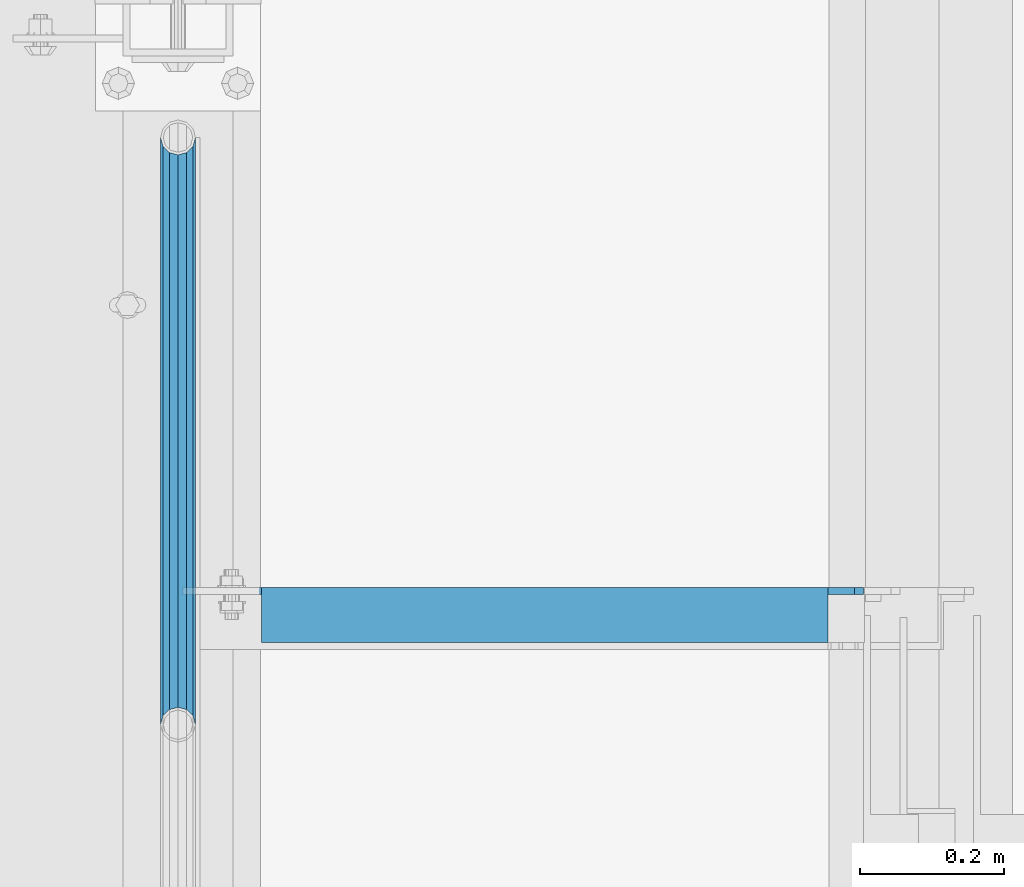
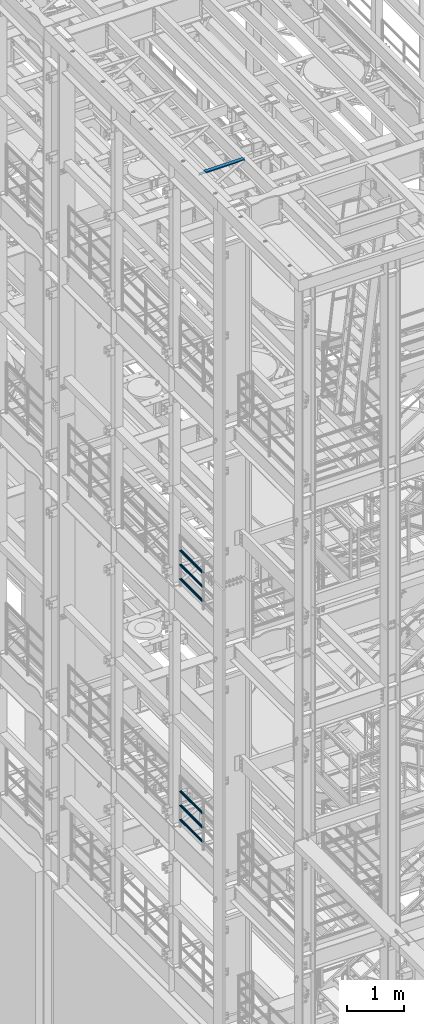
# One storey, part 1179 of 1876: 7 beams, 3 elements without a shape of their own.
"""IFC2X3 building model written with IfcOpenShell, lengths in millimetres."""

from ifc_helpers import new_model, si_unit, frame, origin_with_axes, place, context, subcontext, project, spatial, faceted_brep, material, type_object, element, aggregate, save


model = new_model("IFC2X3")

# Units and contexts
model_context = context("Model", 3, precision=1e-05, world=origin_with_axes())
body_context = subcontext(model_context, "Body", "Model", "MODEL_VIEW")
ifc_project = project(units=[si_unit("LENGTHUNIT", "METRE", prefix="MILLI"), si_unit("AREAUNIT", "SQUARE_METRE"), si_unit("VOLUMEUNIT", "CUBIC_METRE"), si_unit("MASSUNIT", "GRAM", prefix="KILO"), si_unit("TIMEUNIT", "SECOND"), si_unit("PLANEANGLEUNIT", "RADIAN"), si_unit("SOLIDANGLEUNIT", "STERADIAN"), si_unit("THERMODYNAMICTEMPERATUREUNIT", "DEGREE_CELSIUS"), si_unit("LUMINOUSINTENSITYUNIT", "LUMEN")], contexts=[model_context])

# Site, building, storey
site_placement = place(None, origin_with_axes())
site = spatial("IfcSite", under=ifc_project, at=site_placement, CompositionType="ELEMENT")
building_placement = place(site_placement, origin_with_axes())
building = spatial("IfcBuilding", under=site, at=building_placement, Name="Undefined", CompositionType="ELEMENT")
storey_placement = place(building_placement, origin_with_axes())
storey = spatial("IfcBuildingStorey", under=building, at=storey_placement, Name="Undefined", CompositionType="ELEMENT", Elevation=0.0)

# Assembly, beams
assembly_1_placement = place(storey_placement, origin_with_axes())
assembly_1 = element("IfcElementAssembly", 1, at=assembly_1_placement, inside=storey, Name="RAIL", AssemblyPlace="NOTDEFINED", PredefinedType="RIGID_FRAME")
ifc_material_1 = material()
beam_type_1 = type_object("IfcBeamType", Name="PIPE1-1/2SCH40", PredefinedType="NOTDEFINED")
beam_1_placement = place(assembly_1_placement, frame((3.15234098531586e-11, -2729.3062, 13471.525), z_axis=(0.0, 0.0, 1.0), x_axis=(0.0, -1.0, 0.0)))
beam_1 = element("IfcBeam", 2, at=beam_1_placement, type_object=beam_type_1, material=ifc_material_1, Name="RAIL", ObjectType="PIPE1-1/2SCH40", context=body_context, shape_type="Brep", body=[
    faceted_brep([(792.499707006684, -12.0649999999996, 20.8971929933177), (792.499707006684, -12.0650000000314, 15.8661214311469), (792.006278568813, -10.2235000000001, 17.7076214311819), (789.266900000001, -9.09494701772928e-13, 20.4470000000001), (789.266900000001, -9.09494701772928e-13, 24.130000000001), (792.00627856883, 10.2235000000001, 17.7076214311819), (792.499707006684, 12.0649999999678, 15.8661214312124), (792.499707006684, 12.0649999999996, 20.8971929933177), (813.396900000002, 24.1300000000001, 0.0), (801.331900000001, 20.8971929933186, 12.0649999999987), (801.331900000001, 20.8971929933186, -12.0649999999987), (798.142328437896, 17.7076214311801, 10.2235000000001), (800.881707006714, 20.4470000000001, 0.0), (798.142328437896, 17.7076214311801, -10.2235000000001), (792.499707006684, 12.0649999999678, -15.8661214312124), (792.499707006684, 12.0649999999996, -20.8971929933177), (792.00627856883, 10.2235000000001, -17.7076214311819), (789.266900000001, 0.0, -20.4470000000001), (789.266900000001, 0.0, -24.130000000001), (792.499707006684, -12.0650000000314, -15.8661214311469), (792.499707006684, -12.0649999999996, -20.8971929933177), (792.006278568813, -10.2235000000001, -17.7076214311819), (813.396900000002, -24.1300000000319, 0.0), (801.331900000001, -20.8971929933186, -12.0649999999987), (801.331900000001, -20.8971929933186, 12.0649999999987), (798.142328437831, -17.7076214311801, -10.2235000000001), (800.881707006651, -20.4470000000001, 0.0), (798.142328437831, -17.7076214311801, 10.2235000000001), (12.0650000000064, -20.8971929933177, -12.0649999999987), (20.8971929933249, -12.0650000000005, -20.8971929933177), (0.0, 24.1299999999992, 0.0), (12.0650000000064, 20.8971929933177, -12.0649999999987), (12.0650000000064, 20.8971929933177, 12.0649999999987), (20.8971929933249, 12.0650000000005, 20.8971929933177), (24.1300000000064, 0.0, 24.130000000001), (20.8971929933249, 12.0650000000005, -20.8971929933177), (24.1300000000063, 0.0, -24.130000000001), (24.1300000000063, 0.0, -20.4470000000001), (20.8971929933249, -12.0650000000005, -15.8661214311796), (21.3906214311868, -10.2235000000001, -17.7076214311819), (21.3906214311868, 10.2235000000001, -17.7076214311819), (20.8971929933249, 12.0650000000005, -15.8661214311796), (15.2545715621445, 17.7076214311801, -10.2235000000001), (12.5151929933249, 20.4470000000001, 0.0), (15.2545715621445, 17.7076214311801, 10.2235000000001), (20.8971929933249, 12.0650000000005, 15.8661214311796), (21.3906214311868, 10.2235000000001, 17.7076214311819), (24.1300000000064, 0.0, 20.4470000000001), (21.3906214311868, -10.2235000000001, 17.7076214311819), (20.8971929933249, -12.0650000000005, 15.8661214311796), (20.8971929933249, -12.0650000000005, 20.8971929933177), (12.0650000000064, -20.8971929933177, 12.0649999999987), (0.0, -24.1299999999992, 0.0), (15.2545715621445, -17.7076214311801, 10.2235000000001), (12.5151929933249, -20.4470000000001, 0.0), (15.2545715621445, -17.7076214311801, -10.2235000000001)], [[[0, 1, 2, 3, 4]], [[4, 3, 5, 6, 7]], [[8, 9, 10]], [[7, 6, 11, 12, 13, 14, 15, 10, 9]], [[16, 17, 18, 15, 14]], [[19, 20, 18, 17, 21]], [[22, 23, 24]], [[24, 23, 20, 19, 25, 26, 27, 1, 0]], [[28, 29, 20, 23]], [[30, 31, 32]], [[33, 34, 4, 7]], [[32, 33, 7, 9]], [[30, 32, 9, 8]], [[31, 30, 8, 10]], [[35, 31, 10, 15]], [[36, 35, 15, 18]], [[29, 36, 18, 20]], [[37, 36, 29, 38, 39]], [[40, 41, 35, 36, 37]], [[32, 31, 35, 41, 42, 43, 44, 45, 33]], [[33, 45, 46, 47, 34]], [[34, 47, 48, 49, 50]], [[34, 50, 0, 4]], [[50, 51, 24, 0]], [[51, 52, 22, 24]], [[52, 28, 23, 22]], [[51, 28, 52]], [[50, 49, 53, 54, 55, 38, 29, 28, 51]], [[55, 54, 26, 25]], [[21, 39, 38, 55, 25, 19]], [[37, 39, 21, 17]], [[40, 37, 17, 16]], [[42, 41, 40, 16, 14, 13]], [[43, 42, 13, 12]], [[44, 43, 12, 11]], [[5, 46, 45, 44, 11, 6]], [[47, 46, 5, 3]], [[48, 47, 3, 2]], [[53, 49, 48, 2, 1, 27]], [[54, 53, 27, 26]]]),
])
beam_2_placement = place(assembly_1_placement, frame((-1.81898940354586e-12, -3542.7031, 13776.325), z_axis=(0.0, 0.0, -1.0), x_axis=(0.0, 1.0, 0.0)))
beam_2 = element("IfcBeam", 3, at=beam_2_placement, type_object=beam_type_1, material=ifc_material_1, Name="RAIL", ObjectType="PIPE1-1/2SCH40", context=body_context, shape_type="Brep", body=[
    faceted_brep([(0.0, 24.1299999999992, 0.0), (12.0650000000064, 20.8971929933177, -12.0649999999987), (12.0650000000064, 20.8971929933177, 12.0649999999987), (12.0650000000064, -20.8971929933177, 12.0649999999987), (12.0650000000064, -20.8971929933177, -12.0649999999987), (0.0, -24.1299999999992, 0.0), (20.8971929933249, -12.0650000000005, 20.8971929933177), (20.8971929933249, -12.0650000000005, 15.8661214311796), (15.2545715621445, -17.7076214311801, 10.2235000000001), (12.5151929933249, -20.4470000000001, 0.0), (15.2545715621445, -17.7076214311801, -10.2235000000001), (20.8971929933249, -12.0650000000005, -15.8661214311796), (20.8971929933249, -12.0650000000005, -20.8971929933177), (24.1300000000063, 0.0, -20.4470000000001), (24.1300000000063, 0.0, -24.130000000001), (21.3906214311868, -10.2235000000001, -17.7076214311819), (21.3906214311868, 10.2235000000001, -17.7076214311819), (20.8971929933249, 12.0650000000005, -15.8661214311796), (20.8971929933249, 12.0650000000005, -20.8971929933177), (15.2545715621445, 17.7076214311801, -10.2235000000001), (12.5151929933249, 20.4470000000001, 0.0), (15.2545715621445, 17.7076214311801, 10.2235000000001), (20.8971929933249, 12.0650000000005, 15.8661214311796), (20.8971929933249, 12.0650000000005, 20.8971929933177), (21.3906214311868, 10.2235000000001, 17.7076214311819), (24.1300000000064, 0.0, 20.4470000000001), (24.1300000000064, 0.0, 24.130000000001), (21.3906214311868, -10.2235000000001, 17.7076214311819), (813.396900000002, 24.1300000000001, 0.0), (801.331900000001, 20.8971929933186, -12.0649999999987), (792.499707006684, 12.0649999999996, -20.8971929933177), (813.396900000002, -24.1300000000319, 0.0), (801.331900000001, -20.8971929933186, -12.0649999999987), (801.331900000001, -20.8971929933186, 12.0649999999987), (792.499707006684, -12.0649999999996, 20.8971929933177), (792.499707006684, -12.0649999999996, -20.8971929933177), (789.266900000001, 0.0, -24.130000000001), (792.00627856883, 10.2235000000001, -17.7076214311819), (789.266900000001, 0.0, -20.4470000000001), (792.499707006684, 12.0649999999678, -15.8661214312124), (792.499707006684, -12.0650000000314, -15.8661214311469), (792.006278568813, -10.2235000000001, -17.7076214311819), (798.142328437831, -17.7076214311801, -10.2235000000001), (800.881707006651, -20.4470000000001, 0.0), (798.142328437831, -17.7076214311801, 10.2235000000001), (792.499707006684, -12.0650000000314, 15.8661214311469), (792.006278568813, -10.2235000000001, 17.7076214311819), (789.266900000001, -9.09494701772928e-13, 20.4470000000001), (789.266900000001, -9.09494701772928e-13, 24.130000000001), (792.499707006684, 12.0649999999996, 20.8971929933177), (801.331900000001, 20.8971929933186, 12.0649999999987), (792.499707006684, 12.0649999999678, 15.8661214312124), (798.142328437896, 17.7076214311801, 10.2235000000001), (800.881707006714, 20.4470000000001, 0.0), (798.142328437896, 17.7076214311801, -10.2235000000001), (792.00627856883, 10.2235000000001, 17.7076214311819)], [[[0, 1, 2]], [[3, 4, 5]], [[6, 7, 8, 9, 10, 11, 12, 4, 3]], [[13, 14, 12, 11, 15]], [[16, 17, 18, 14, 13]], [[2, 1, 18, 17, 19, 20, 21, 22, 23]], [[23, 22, 24, 25, 26]], [[26, 25, 27, 7, 6]], [[1, 0, 28, 29]], [[18, 1, 29, 30]], [[31, 32, 33]], [[6, 3, 33, 34]], [[3, 5, 31, 33]], [[5, 4, 32, 31]], [[4, 12, 35, 32]], [[12, 14, 36, 35]], [[14, 18, 30, 36]], [[37, 38, 36, 30, 39]], [[40, 35, 36, 38, 41]], [[33, 32, 35, 40, 42, 43, 44, 45, 34]], [[34, 45, 46, 47, 48]], [[26, 6, 34, 48]], [[2, 23, 49, 50]], [[23, 26, 48, 49]], [[0, 2, 50, 28]], [[28, 50, 29]], [[49, 51, 52, 53, 54, 39, 30, 29, 50]], [[48, 47, 55, 51, 49]], [[25, 24, 55, 47]], [[55, 24, 22, 21, 52, 51]], [[21, 20, 53, 52]], [[20, 19, 54, 53]], [[19, 17, 16, 37, 39, 54]], [[16, 13, 38, 37]], [[13, 15, 41, 38]], [[41, 15, 11, 10, 42, 40]], [[10, 9, 43, 42]], [[9, 8, 44, 43]], [[8, 7, 27, 46, 45, 44]], [[27, 25, 47, 46]]]),
])
beam_3_placement = place(assembly_1_placement, frame((-1.81898940354586e-12, -3542.7031, 14081.125), z_axis=(0.0, 0.0, -1.0), x_axis=(0.0, 1.0, 0.0)))
beam_3 = element("IfcBeam", 4, at=beam_3_placement, type_object=beam_type_1, material=ifc_material_1, Name="RAIL", ObjectType="PIPE1-1/2SCH40", context=body_context, shape_type="Brep", body=[
    faceted_brep([(0.0, 24.1299999999992, 0.0), (12.0650000000064, 20.8971929933177, -12.0649999999987), (12.0650000000064, 20.8971929933177, 12.0649999999987), (12.0650000000064, -20.8971929933177, 12.0649999999987), (12.0650000000064, -20.8971929933177, -12.0649999999987), (0.0, -24.1299999999992, 0.0), (20.8971929933249, -12.0650000000005, 20.8971929933177), (20.8971929933249, -12.0650000000005, 15.8661214311796), (15.2545715621445, -17.7076214311801, 10.2235000000001), (12.5151929933249, -20.4470000000001, 0.0), (15.2545715621445, -17.7076214311801, -10.2235000000001), (20.8971929933249, -12.0650000000005, -15.8661214311796), (20.8971929933249, -12.0650000000005, -20.8971929933177), (24.1300000000063, 0.0, -20.4470000000001), (24.1300000000063, 0.0, -24.130000000001), (21.3906214311868, -10.2235000000001, -17.7076214311819), (21.3906214311868, 10.2235000000001, -17.7076214311819), (20.8971929933249, 12.0650000000005, -15.8661214311796), (20.8971929933249, 12.0650000000005, -20.8971929933177), (15.2545715621445, 17.7076214311801, -10.2235000000001), (12.5151929933249, 20.4470000000001, 0.0), (15.2545715621445, 17.7076214311801, 10.2235000000001), (20.8971929933249, 12.0650000000005, 15.8661214311796), (20.8971929933249, 12.0650000000005, 20.8971929933177), (21.3906214311868, 10.2235000000001, 17.7076214311819), (24.1300000000064, 0.0, 20.4470000000001), (24.1300000000064, 0.0, 24.130000000001), (21.3906214311868, -10.2235000000001, 17.7076214311819), (813.396900000002, 24.1300000000001, 0.0), (801.331900000001, 20.8971929933186, -12.0649999999987), (792.499707006684, 12.0649999999996, -20.8971929933177), (813.396900000002, -24.1300000000319, 0.0), (801.331900000001, -20.8971929933186, -12.0649999999987), (801.331900000001, -20.8971929933186, 12.0649999999987), (792.499707006684, -12.0649999999996, 20.8971929933177), (792.499707006684, -12.0649999999996, -20.8971929933177), (789.266900000001, 0.0, -24.130000000001), (792.00627856883, 10.2235000000001, -17.7076214311819), (789.266900000001, 0.0, -20.4470000000001), (792.499707006684, 12.0649999999678, -15.8661214312124), (792.499707006684, -12.0650000000314, -15.8661214311469), (792.006278568813, -10.2235000000001, -17.7076214311819), (798.142328437831, -17.7076214311801, -10.2235000000001), (800.881707006651, -20.4470000000001, 0.0), (798.142328437831, -17.7076214311801, 10.2235000000001), (792.499707006684, -12.0650000000314, 15.8661214311469), (792.006278568813, -10.2235000000001, 17.7076214311819), (789.266900000001, -9.09494701772928e-13, 20.4470000000001), (789.266900000001, -9.09494701772928e-13, 24.130000000001), (792.499707006684, 12.0649999999996, 20.8971929933177), (801.331900000001, 20.8971929933186, 12.0649999999987), (792.499707006684, 12.0649999999678, 15.8661214312124), (798.142328437896, 17.7076214311801, 10.2235000000001), (800.881707006714, 20.4470000000001, 0.0), (798.142328437896, 17.7076214311801, -10.2235000000001), (792.00627856883, 10.2235000000001, 17.7076214311819)], [[[0, 1, 2]], [[3, 4, 5]], [[6, 7, 8, 9, 10, 11, 12, 4, 3]], [[13, 14, 12, 11, 15]], [[16, 17, 18, 14, 13]], [[2, 1, 18, 17, 19, 20, 21, 22, 23]], [[23, 22, 24, 25, 26]], [[26, 25, 27, 7, 6]], [[1, 0, 28, 29]], [[18, 1, 29, 30]], [[31, 32, 33]], [[6, 3, 33, 34]], [[3, 5, 31, 33]], [[5, 4, 32, 31]], [[4, 12, 35, 32]], [[12, 14, 36, 35]], [[14, 18, 30, 36]], [[37, 38, 36, 30, 39]], [[40, 35, 36, 38, 41]], [[33, 32, 35, 40, 42, 43, 44, 45, 34]], [[34, 45, 46, 47, 48]], [[26, 6, 34, 48]], [[2, 23, 49, 50]], [[23, 26, 48, 49]], [[0, 2, 50, 28]], [[28, 50, 29]], [[49, 51, 52, 53, 54, 39, 30, 29, 50]], [[48, 47, 55, 51, 49]], [[25, 24, 55, 47]], [[55, 24, 22, 21, 52, 51]], [[21, 20, 53, 52]], [[20, 19, 54, 53]], [[19, 17, 16, 37, 39, 54]], [[16, 13, 38, 37]], [[13, 15, 41, 38]], [[41, 15, 11, 10, 42, 40]], [[10, 9, 43, 42]], [[9, 8, 44, 43]], [[8, 7, 27, 46, 45, 44]], [[27, 25, 47, 46]]]),
])
aggregate(assembly_1, [beam_1, beam_2, beam_3])

assembly_2_placement = place(storey_placement, origin_with_axes())
assembly_2 = element("IfcElementAssembly", 5, at=assembly_2_placement, inside=storey, Name="RAIL", AssemblyPlace="NOTDEFINED", PredefinedType="RIGID_FRAME")
beam_4_placement = place(assembly_2_placement, frame((1.95728346174738e-11, -2729.3062, 8315.325), z_axis=(0.0, 0.0, 1.0), x_axis=(0.0, -1.0, 0.0)))
beam_4 = element("IfcBeam", 6, at=beam_4_placement, type_object=beam_type_1, material=ifc_material_1, Name="RAIL", ObjectType="PIPE1-1/2SCH40", context=body_context, shape_type="Brep", body=[
    faceted_brep([(792.499707006684, -12.0649999999996, 20.8971929933177), (792.499707006684, -12.0650000000314, 15.8661214311469), (792.006278568813, -10.2235000000001, 17.7076214311819), (789.266900000001, -9.09494701772928e-13, 20.4470000000001), (789.266900000001, -9.09494701772928e-13, 24.130000000001), (792.00627856883, 10.2235000000001, 17.7076214311819), (792.499707006684, 12.0649999999678, 15.8661214312124), (792.499707006684, 12.0649999999996, 20.8971929933177), (813.396900000002, 24.1300000000001, 0.0), (801.331900000001, 20.8971929933186, 12.0649999999987), (801.331900000001, 20.8971929933186, -12.0649999999987), (798.142328437896, 17.7076214311801, 10.2235000000001), (800.881707006714, 20.4470000000001, 0.0), (798.142328437896, 17.7076214311801, -10.2235000000001), (792.499707006684, 12.0649999999678, -15.8661214312124), (792.499707006684, 12.0649999999996, -20.8971929933177), (792.00627856883, 10.2235000000001, -17.7076214311819), (789.266900000001, 0.0, -20.4470000000001), (789.266900000001, 0.0, -24.130000000001), (792.499707006684, -12.0650000000314, -15.8661214311469), (792.499707006684, -12.0649999999996, -20.8971929933177), (792.006278568813, -10.2235000000001, -17.7076214311819), (813.396900000002, -24.1300000000319, 0.0), (801.331900000001, -20.8971929933186, -12.0649999999987), (801.331900000001, -20.8971929933186, 12.0649999999987), (798.142328437831, -17.7076214311801, -10.2235000000001), (800.881707006651, -20.4470000000001, 0.0), (798.142328437831, -17.7076214311801, 10.2235000000001), (12.0650000000064, -20.8971929933177, -12.0649999999987), (20.8971929933249, -12.0650000000005, -20.8971929933177), (0.0, 24.1299999999992, 0.0), (12.0650000000064, 20.8971929933177, -12.0649999999987), (12.0650000000064, 20.8971929933177, 12.0649999999987), (20.8971929933249, 12.0650000000005, 20.8971929933177), (24.1300000000064, 0.0, 24.130000000001), (20.8971929933249, 12.0650000000005, -20.8971929933177), (24.1300000000063, 0.0, -24.130000000001), (24.1300000000063, 0.0, -20.4470000000001), (20.8971929933249, -12.0650000000005, -15.8661214311796), (21.3906214311868, -10.2235000000001, -17.7076214311819), (21.3906214311868, 10.2235000000001, -17.7076214311819), (20.8971929933249, 12.0650000000005, -15.8661214311796), (15.2545715621445, 17.7076214311801, -10.2235000000001), (12.5151929933249, 20.4470000000001, 0.0), (15.2545715621445, 17.7076214311801, 10.2235000000001), (20.8971929933249, 12.0650000000005, 15.8661214311796), (21.3906214311868, 10.2235000000001, 17.7076214311819), (24.1300000000064, 0.0, 20.4470000000001), (21.3906214311868, -10.2235000000001, 17.7076214311819), (20.8971929933249, -12.0650000000005, 15.8661214311796), (20.8971929933249, -12.0650000000005, 20.8971929933177), (12.0650000000064, -20.8971929933177, 12.0649999999987), (0.0, -24.1299999999992, 0.0), (15.2545715621445, -17.7076214311801, 10.2235000000001), (12.5151929933249, -20.4470000000001, 0.0), (15.2545715621445, -17.7076214311801, -10.2235000000001)], [[[0, 1, 2, 3, 4]], [[4, 3, 5, 6, 7]], [[8, 9, 10]], [[7, 6, 11, 12, 13, 14, 15, 10, 9]], [[16, 17, 18, 15, 14]], [[19, 20, 18, 17, 21]], [[22, 23, 24]], [[24, 23, 20, 19, 25, 26, 27, 1, 0]], [[28, 29, 20, 23]], [[30, 31, 32]], [[33, 34, 4, 7]], [[32, 33, 7, 9]], [[30, 32, 9, 8]], [[31, 30, 8, 10]], [[35, 31, 10, 15]], [[36, 35, 15, 18]], [[29, 36, 18, 20]], [[37, 36, 29, 38, 39]], [[40, 41, 35, 36, 37]], [[32, 31, 35, 41, 42, 43, 44, 45, 33]], [[33, 45, 46, 47, 34]], [[34, 47, 48, 49, 50]], [[34, 50, 0, 4]], [[50, 51, 24, 0]], [[51, 52, 22, 24]], [[52, 28, 23, 22]], [[51, 28, 52]], [[50, 49, 53, 54, 55, 38, 29, 28, 51]], [[55, 54, 26, 25]], [[21, 39, 38, 55, 25, 19]], [[37, 39, 21, 17]], [[40, 37, 17, 16]], [[42, 41, 40, 16, 14, 13]], [[43, 42, 13, 12]], [[44, 43, 12, 11]], [[5, 46, 45, 44, 11, 6]], [[47, 46, 5, 3]], [[48, 47, 3, 2]], [[53, 49, 48, 2, 1, 27]], [[54, 53, 27, 26]]]),
])
beam_5_placement = place(assembly_2_placement, frame((-1.81898940354586e-12, -3542.7031, 8620.125), z_axis=(0.0, 0.0, -1.0), x_axis=(0.0, 1.0, 0.0)))
beam_5 = element("IfcBeam", 7, at=beam_5_placement, type_object=beam_type_1, material=ifc_material_1, Name="RAIL", ObjectType="PIPE1-1/2SCH40", context=body_context, shape_type="Brep", body=[
    faceted_brep([(0.0, 24.1299999999992, 0.0), (12.0650000000064, 20.8971929933177, -12.0649999999987), (12.0650000000064, 20.8971929933177, 12.0649999999987), (12.0650000000064, -20.8971929933177, 12.0649999999987), (12.0650000000064, -20.8971929933177, -12.0649999999987), (0.0, -24.1299999999992, 0.0), (20.8971929933249, -12.0650000000005, 20.8971929933177), (20.8971929933249, -12.0650000000005, 15.8661214311796), (15.2545715621445, -17.7076214311801, 10.2235000000001), (12.5151929933249, -20.4470000000001, 0.0), (15.2545715621445, -17.7076214311801, -10.2235000000001), (20.8971929933249, -12.0650000000005, -15.8661214311796), (20.8971929933249, -12.0650000000005, -20.8971929933177), (24.1300000000063, 0.0, -20.4470000000001), (24.1300000000063, 0.0, -24.130000000001), (21.3906214311868, -10.2235000000001, -17.7076214311819), (21.3906214311868, 10.2235000000001, -17.7076214311819), (20.8971929933249, 12.0650000000005, -15.8661214311796), (20.8971929933249, 12.0650000000005, -20.8971929933177), (15.2545715621445, 17.7076214311801, -10.2235000000001), (12.5151929933249, 20.4470000000001, 0.0), (15.2545715621445, 17.7076214311801, 10.2235000000001), (20.8971929933249, 12.0650000000005, 15.8661214311796), (20.8971929933249, 12.0650000000005, 20.8971929933177), (21.3906214311868, 10.2235000000001, 17.7076214311819), (24.1300000000064, 0.0, 20.4470000000001), (24.1300000000064, 0.0, 24.130000000001), (21.3906214311868, -10.2235000000001, 17.7076214311819), (813.396900000002, 24.1300000000001, 0.0), (801.331900000001, 20.8971929933186, -12.0649999999987), (792.499707006684, 12.0649999999996, -20.8971929933177), (813.396900000002, -24.1300000000319, 0.0), (801.331900000001, -20.8971929933186, -12.0649999999987), (801.331900000001, -20.8971929933186, 12.0649999999987), (792.499707006684, -12.0649999999996, 20.8971929933177), (792.499707006684, -12.0649999999996, -20.8971929933177), (789.266900000001, 0.0, -24.130000000001), (792.00627856883, 10.2235000000001, -17.7076214311819), (789.266900000001, 0.0, -20.4470000000001), (792.499707006684, 12.0649999999678, -15.8661214312124), (792.499707006684, -12.0650000000314, -15.8661214311469), (792.006278568813, -10.2235000000001, -17.7076214311819), (798.142328437831, -17.7076214311801, -10.2235000000001), (800.881707006651, -20.4470000000001, 0.0), (798.142328437831, -17.7076214311801, 10.2235000000001), (792.499707006684, -12.0650000000314, 15.8661214311469), (792.006278568813, -10.2235000000001, 17.7076214311819), (789.266900000001, -9.09494701772928e-13, 20.4470000000001), (789.266900000001, -9.09494701772928e-13, 24.130000000001), (792.499707006684, 12.0649999999996, 20.8971929933177), (801.331900000001, 20.8971929933186, 12.0649999999987), (792.499707006684, 12.0649999999678, 15.8661214312124), (798.142328437896, 17.7076214311801, 10.2235000000001), (800.881707006714, 20.4470000000001, 0.0), (798.142328437896, 17.7076214311801, -10.2235000000001), (792.00627856883, 10.2235000000001, 17.7076214311819)], [[[0, 1, 2]], [[3, 4, 5]], [[6, 7, 8, 9, 10, 11, 12, 4, 3]], [[13, 14, 12, 11, 15]], [[16, 17, 18, 14, 13]], [[2, 1, 18, 17, 19, 20, 21, 22, 23]], [[23, 22, 24, 25, 26]], [[26, 25, 27, 7, 6]], [[1, 0, 28, 29]], [[18, 1, 29, 30]], [[31, 32, 33]], [[6, 3, 33, 34]], [[3, 5, 31, 33]], [[5, 4, 32, 31]], [[4, 12, 35, 32]], [[12, 14, 36, 35]], [[14, 18, 30, 36]], [[37, 38, 36, 30, 39]], [[40, 35, 36, 38, 41]], [[33, 32, 35, 40, 42, 43, 44, 45, 34]], [[34, 45, 46, 47, 48]], [[26, 6, 34, 48]], [[2, 23, 49, 50]], [[23, 26, 48, 49]], [[0, 2, 50, 28]], [[28, 50, 29]], [[49, 51, 52, 53, 54, 39, 30, 29, 50]], [[48, 47, 55, 51, 49]], [[25, 24, 55, 47]], [[55, 24, 22, 21, 52, 51]], [[21, 20, 53, 52]], [[20, 19, 54, 53]], [[19, 17, 16, 37, 39, 54]], [[16, 13, 38, 37]], [[13, 15, 41, 38]], [[41, 15, 11, 10, 42, 40]], [[10, 9, 43, 42]], [[9, 8, 44, 43]], [[8, 7, 27, 46, 45, 44]], [[27, 25, 47, 46]]]),
])
beam_6_placement = place(assembly_2_placement, frame((-1.81898940354586e-12, -3542.7031, 8924.925), z_axis=(0.0, 0.0, -1.0), x_axis=(0.0, 1.0, 0.0)))
beam_6 = element("IfcBeam", 8, at=beam_6_placement, type_object=beam_type_1, material=ifc_material_1, Name="RAIL", ObjectType="PIPE1-1/2SCH40", context=body_context, shape_type="Brep", body=[
    faceted_brep([(0.0, 24.1299999999992, 0.0), (12.0650000000064, 20.8971929933177, -12.0649999999987), (12.0650000000064, 20.8971929933177, 12.0649999999987), (12.0650000000064, -20.8971929933177, 12.0649999999987), (12.0650000000064, -20.8971929933177, -12.0649999999987), (0.0, -24.1299999999992, 0.0), (20.8971929933249, -12.0650000000005, 20.8971929933177), (20.8971929933249, -12.0650000000005, 15.8661214311796), (15.2545715621445, -17.7076214311801, 10.2235000000001), (12.5151929933249, -20.4470000000001, 0.0), (15.2545715621445, -17.7076214311801, -10.2235000000001), (20.8971929933249, -12.0650000000005, -15.8661214311796), (20.8971929933249, -12.0650000000005, -20.8971929933177), (24.1300000000063, 0.0, -20.4470000000001), (24.1300000000063, 0.0, -24.130000000001), (21.3906214311868, -10.2235000000001, -17.7076214311819), (21.3906214311868, 10.2235000000001, -17.7076214311819), (20.8971929933249, 12.0650000000005, -15.8661214311796), (20.8971929933249, 12.0650000000005, -20.8971929933177), (15.2545715621445, 17.7076214311801, -10.2235000000001), (12.5151929933249, 20.4470000000001, 0.0), (15.2545715621445, 17.7076214311801, 10.2235000000001), (20.8971929933249, 12.0650000000005, 15.8661214311796), (20.8971929933249, 12.0650000000005, 20.8971929933177), (21.3906214311868, 10.2235000000001, 17.7076214311819), (24.1300000000064, 0.0, 20.4470000000001), (24.1300000000064, 0.0, 24.130000000001), (21.3906214311868, -10.2235000000001, 17.7076214311819), (813.396900000002, 24.1300000000001, 0.0), (801.331900000001, 20.8971929933186, -12.0649999999987), (792.499707006684, 12.0649999999996, -20.8971929933177), (813.396900000002, -24.1300000000319, 0.0), (801.331900000001, -20.8971929933186, -12.0649999999987), (801.331900000001, -20.8971929933186, 12.0649999999987), (792.499707006684, -12.0649999999996, 20.8971929933177), (792.499707006684, -12.0649999999996, -20.8971929933177), (789.266900000001, 0.0, -24.130000000001), (792.00627856883, 10.2235000000001, -17.7076214311819), (789.266900000001, 0.0, -20.4470000000001), (792.499707006684, 12.0649999999678, -15.8661214312124), (792.499707006684, -12.0650000000314, -15.8661214311469), (792.006278568813, -10.2235000000001, -17.7076214311819), (798.142328437831, -17.7076214311801, -10.2235000000001), (800.881707006651, -20.4470000000001, 0.0), (798.142328437831, -17.7076214311801, 10.2235000000001), (792.499707006684, -12.0650000000314, 15.8661214311469), (792.006278568813, -10.2235000000001, 17.7076214311819), (789.266900000001, -9.09494701772928e-13, 20.4470000000001), (789.266900000001, -9.09494701772928e-13, 24.130000000001), (792.499707006684, 12.0649999999996, 20.8971929933177), (801.331900000001, 20.8971929933186, 12.0649999999987), (792.499707006684, 12.0649999999678, 15.8661214312124), (798.142328437896, 17.7076214311801, 10.2235000000001), (800.881707006714, 20.4470000000001, 0.0), (798.142328437896, 17.7076214311801, -10.2235000000001), (792.00627856883, 10.2235000000001, 17.7076214311819)], [[[0, 1, 2]], [[3, 4, 5]], [[6, 7, 8, 9, 10, 11, 12, 4, 3]], [[13, 14, 12, 11, 15]], [[16, 17, 18, 14, 13]], [[2, 1, 18, 17, 19, 20, 21, 22, 23]], [[23, 22, 24, 25, 26]], [[26, 25, 27, 7, 6]], [[1, 0, 28, 29]], [[18, 1, 29, 30]], [[31, 32, 33]], [[6, 3, 33, 34]], [[3, 5, 31, 33]], [[5, 4, 32, 31]], [[4, 12, 35, 32]], [[12, 14, 36, 35]], [[14, 18, 30, 36]], [[37, 38, 36, 30, 39]], [[40, 35, 36, 38, 41]], [[33, 32, 35, 40, 42, 43, 44, 45, 34]], [[34, 45, 46, 47, 48]], [[26, 6, 34, 48]], [[2, 23, 49, 50]], [[23, 26, 48, 49]], [[0, 2, 50, 28]], [[28, 50, 29]], [[49, 51, 52, 53, 54, 39, 30, 29, 50]], [[48, 47, 55, 51, 49]], [[25, 24, 55, 47]], [[55, 24, 22, 21, 52, 51]], [[21, 20, 53, 52]], [[20, 19, 54, 53]], [[19, 17, 16, 37, 39, 54]], [[16, 13, 38, 37]], [[13, 15, 41, 38]], [[41, 15, 11, 10, 42, 40]], [[10, 9, 43, 42]], [[9, 8, 44, 43]], [[8, 7, 27, 46, 45, 44]], [[27, 25, 47, 46]]]),
])
aggregate(assembly_2, [beam_4, beam_5, beam_6])

# Assembly, beam
assembly_3_placement = place(storey_placement, origin_with_axes())
assembly_3 = element("IfcElementAssembly", 9, at=assembly_3_placement, inside=storey, Name="ANGLE", AssemblyPlace="NOTDEFINED", PredefinedType="RIGID_FRAME")
ifc_material_2 = material(Name="STEEL/A36")
beam_type_2 = type_object("IfcBeamType", Name="L3X3X3/8", PredefinedType="NOTDEFINED")
beam_7_placement = place(assembly_3_placement, frame((4.51516825708356e-09, -3390.9, 22517.1), z_axis=(0.0, -1.0, 0.0), x_axis=(1.0, 0.0, 0.0)))
beam_7 = element("IfcBeam", 10, at=beam_7_placement, type_object=beam_type_2, material=ifc_material_2, Name="ANGLE", ObjectType="L3X3X3/8", context=body_context, shape_type="Brep", body=[
    faceted_brep([(115.886999817316, 28.5750000000007, 38.0999999999999), (115.886999817316, 38.0999999999985, 38.0999999999999), (115.886998826692, 38.0999999999985, -38.0999999999999), (115.88699882669, 12.699999237062, -38.0999999999999), (115.886998950515, 12.699999237062, -28.5749999999998), (115.88699895052, 28.5750000000007, -28.5749999999998), (38.8937432114558, 12.699999237062, -38.0999999999999), (38.8937433352807, 12.699999237062, -28.5749999999998), (7.14374321145577, -19.050000762938, -38.0999999999999), (7.14374333528067, -19.050000762938, -28.5749999999998), (7.1437499954859, -38.0999999999985, -38.0999999999999), (7.1437499954859, -38.0999999999985, -28.5749999999998), (949.325002419604, 15.8750003814712, -28.5749999999998), (936.625002610339, 28.5750000000007, -28.5749999999998), (900.113000619098, 28.5750000000007, -28.5749999999998), (949.324999995485, -38.0999999999985, -28.5749999999998), (949.325002419604, 3.17500152588036, -28.5749999999998), (900.11300241932, 28.5750000000007, 38.0999999999999), (900.1130024193, 38.0999999999985, 38.0999999999999), (900.113000361957, 38.0999999999985, -38.0999999999999), (900.113000361924, 28.5750001907363, -38.0999999999999), (936.625002353164, 28.5750001907363, -38.0999999999999), (949.325002162429, 15.8750003814712, -38.0999999999999), (949.325002162429, 3.17500152588036, -38.0999999999999), (949.324999995485, -38.0999999999985, -38.0999999999999)], [[[0, 1, 2, 3, 4, 5]], [[4, 3, 6, 7]], [[7, 6, 8, 9]], [[8, 10, 11, 9]], [[12, 13, 14, 5, 4, 7, 9, 11, 15, 16]], [[0, 5, 14, 17]], [[1, 0, 17, 18]], [[2, 1, 18, 19]], [[17, 14, 20, 19, 18]], [[13, 21, 20, 14]], [[12, 22, 21, 13]], [[16, 23, 22, 12]], [[10, 8, 6, 3, 2, 19, 20, 21, 22, 23, 24]], [[11, 10, 24, 15]], [[23, 16, 15, 24]]]),
])
aggregate(assembly_3, [beam_7])

save(model, "model.ifc")
